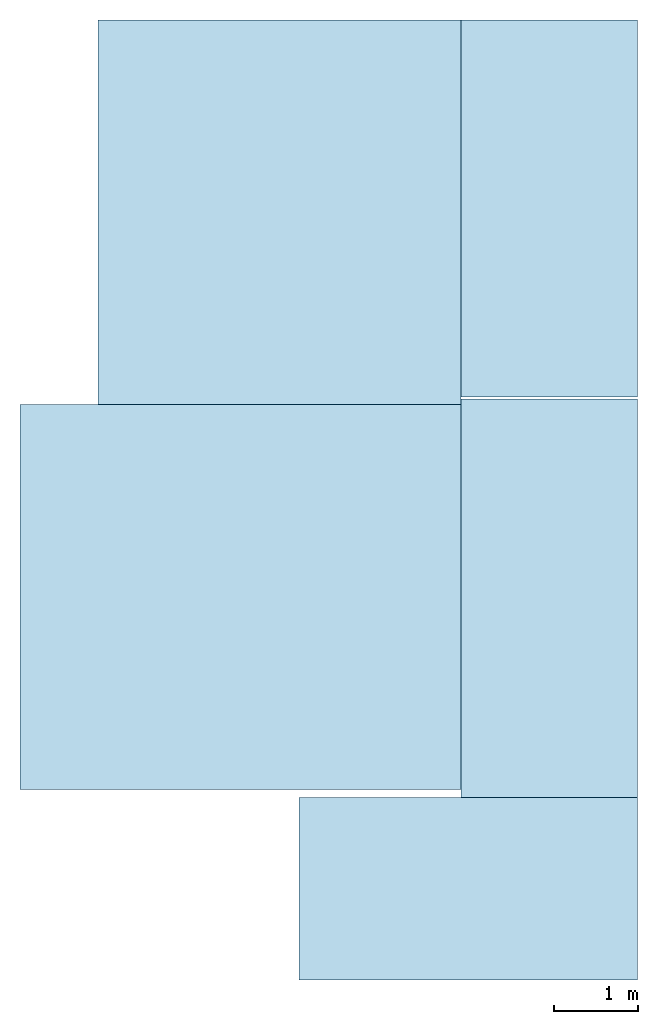
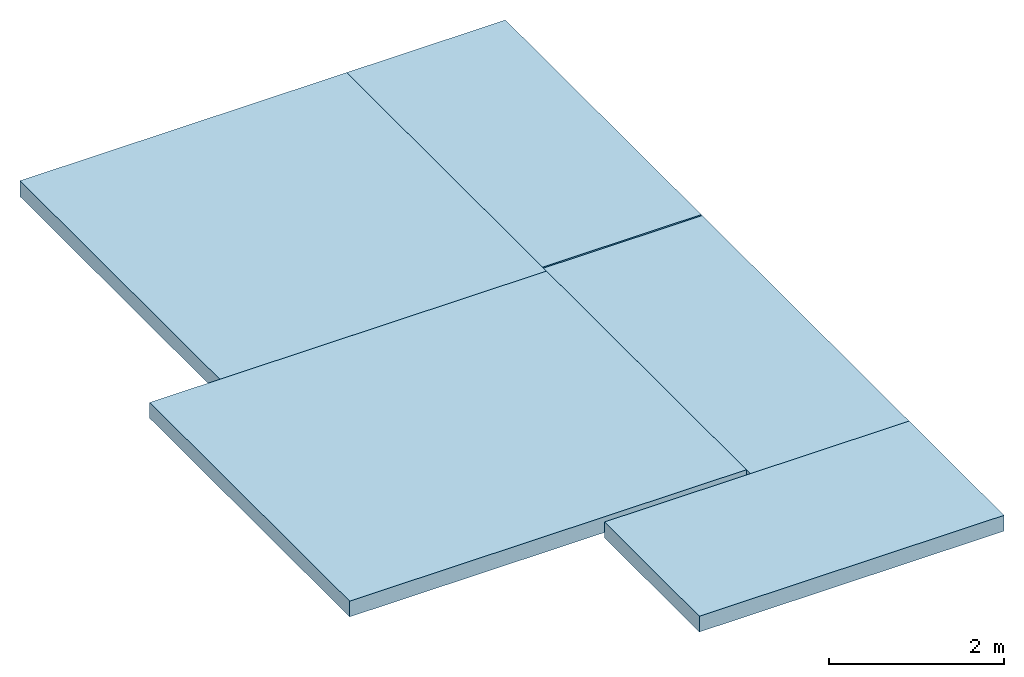
# One storey: 5 slabs.
"""IFC2X3 building model written with IfcOpenShell, lengths in millimetres."""

import ifcopenshell
import ifcopenshell.guid

model = None  # the IFC model being written
_history = None  # IfcOwnerHistory: only IFC2X3 demands one
_inside = {}  # id of a spatial element -> (the spatial element, [elements in it])
_under = {}  # id of a project, library or spatial element -> (it, [spatial elements below it])
_declared = {}  # id of a project -> (the project, [libraries it declares])
_typed = {}  # id of a type object -> (the type object, [elements of that type])
_made_of = {}  # id of a material, layer set ... -> (it, [elements and type objects made of it])


def new_model(schema):
    """Start an empty IFC model of exactly this schema.

    Asked for "IFC4X3", IfcOpenShell would pick the latest addendum, in which some entities
    have other attributes; the version numbers below select the first issue.
    IFC2X3 requires an IfcOwnerHistory on every rooted entity: one is made here for all.
    """
    global model, _history
    if schema == "IFC4X3":
        model = ifcopenshell.file(schema_version=(4, 3, 0, 0))
    else:
        model = ifcopenshell.file(schema=schema)
    _inside.clear()
    _under.clear()
    _declared.clear()
    _typed.clear()
    _made_of.clear()
    _history = None
    if model.schema == "IFC2X3":
        org = make("IfcOrganization", Name="unknown")
        user = make(
            "IfcPersonAndOrganization",
            ThePerson=make("IfcPerson", FamilyName="unknown"),
            TheOrganization=org,
        )
        app = make(
            "IfcApplication",
            ApplicationDeveloper=org,
            Version="unknown",
            ApplicationFullName="unknown",
            ApplicationIdentifier="unknown",
        )
        _history = make(
            "IfcOwnerHistory",
            OwningUser=user,
            OwningApplication=app,
            ChangeAction="ADDED",
            CreationDate=0,
        )
    return model


def make(cls, **values):
    """One entity of the class cls with the attributes given. An attribute that is None is left unset."""
    return model.create_entity(
        cls, **{name: value for name, value in values.items() if value is not None}
    )


def entity(cls, *values):
    """Any entity or typed value of the class cls, its attributes in the order of the schema. None: left unset."""
    e = model.create_entity(cls)
    for i, value in enumerate(values):
        if value is not None:
            e[i] = value
    return e


def rooted(cls, **values):
    """An entity with a GlobalId (a new one), such as an element, a storey or a relation."""
    return make(cls, GlobalId=ifcopenshell.guid.new(), OwnerHistory=_history, **values)


def si_unit(unit_type, name, prefix=None):
    """IfcSIUnit, for example si_unit("LENGTHUNIT", "METRE", prefix="MILLI")."""
    return make("IfcSIUnit", UnitType=unit_type, Prefix=prefix, Name=name)


def converted_unit(unit_type, name, factor, base, dimensions=None, offset=None):
    """IfcConversionBasedUnit, such as the inch: factor (a typed value) times the base unit."""
    return make(
        "IfcConversionBasedUnit"
        if offset is None
        else "IfcConversionBasedUnitWithOffset",
        ConversionOffset=offset,
        Dimensions=None
        if dimensions is None
        else entity("IfcDimensionalExponents", *dimensions),
        UnitType=unit_type,
        Name=name,
        ConversionFactor=make(
            "IfcMeasureWithUnit", ValueComponent=factor, UnitComponent=base
        ),
    )


def assignment(units):
    """IfcUnitAssignment: the units of a project."""
    return None if units is None else make("IfcUnitAssignment", Units=units)


def point(xyz):
    """IfcCartesianPoint."""
    return None if xyz is None else make("IfcCartesianPoint", Coordinates=xyz)


def direction(xyz):
    """IfcDirection."""
    return None if xyz is None else make("IfcDirection", DirectionRatios=xyz)


def frame(location, z_axis=None, x_axis=None):
    """IfcAxis2Placement3D, a coordinate frame: its origin and axes. An axis left out is left unset."""
    return make(
        "IfcAxis2Placement3D",
        Location=point(location),
        Axis=direction(z_axis),
        RefDirection=direction(x_axis),
    )


def frame_2d(location, x_axis=None):
    """IfcAxis2Placement2D, a coordinate frame in the plane: its origin and x axis."""
    return make(
        "IfcAxis2Placement2D", Location=point(location), RefDirection=direction(x_axis)
    )


def origin():
    """The frame at (0, 0, 0) with its axes left unset."""
    return frame((0.0, 0.0, 0.0))


def place(relative_to, where):
    """IfcLocalPlacement: puts the frame where relative to a parent placement (None: the world)."""
    return make(
        "IfcLocalPlacement", PlacementRelTo=relative_to, RelativePlacement=where
    )


def context(
    kind, dimensions, precision=None, world=None, true_north=None, identifier=None
):
    """IfcGeometricRepresentationContext, for example the 3D "Model" context."""
    return make(
        "IfcGeometricRepresentationContext",
        ContextIdentifier=identifier,
        ContextType=kind,
        CoordinateSpaceDimension=dimensions,
        Precision=precision,
        WorldCoordinateSystem=world,
        TrueNorth=true_north,
    )


def project(units=None, contexts=None):
    """IfcProject with its units and contexts."""
    return rooted(
        "IfcProject",
        Name="project",
        RepresentationContexts=contexts,
        UnitsInContext=assignment(units),
    )


def spatial(cls, under=None, at=None, **own):
    """A site, building, storey or space (cls), placed at a placement, below another one or the project."""
    s = rooted(cls, ObjectPlacement=at, **own)
    if under is not None:
        _under.setdefault(under.id(), (under, []))[1].append(s)
    return s


def profile(cls, at=None, kind="AREA", **sizes):
    """A parametric profile (cls). Its sizes go by their IFC names, for example OverallWidth=200.0."""
    return make(cls, ProfileType=kind, Position=at, **sizes)


def rectangle(**sizes):
    """IfcRectangleProfileDef."""
    return profile("IfcRectangleProfileDef", **sizes)


def extrude(swept, where, along, depth):
    """IfcExtrudedAreaSolid: the profile swept, set in the frame where, extruded along a direction by depth."""
    return make(
        "IfcExtrudedAreaSolid",
        SweptArea=swept,
        Position=where,
        ExtrudedDirection=direction(along),
        Depth=depth,
    )


def shape(context_of_items, identifier, shape_type, items):
    """IfcShapeRepresentation: the items that make up one representation, for example the "Body"."""
    return make(
        "IfcShapeRepresentation",
        ContextOfItems=context_of_items,
        RepresentationIdentifier=identifier,
        RepresentationType=shape_type,
        Items=items,
    )


def material(Name=None, Category=None):
    """IfcMaterial."""
    return make("IfcMaterial", Name=Name, Category=Category)


def layer(
    of_material, thickness, ventilated=None, Name=None, Category=None, Priority=None
):
    """IfcMaterialLayer: one layer of a wall or slab, of a material (None: an air gap)."""
    return make(
        "IfcMaterialLayer",
        Material=of_material,
        LayerThickness=thickness,
        IsVentilated=ventilated,
        Name=Name,
        Category=Category,
        Priority=Priority,
    )


def layer_set(layers, Name=None):
    """IfcMaterialLayerSet."""
    return make("IfcMaterialLayerSet", MaterialLayers=layers, LayerSetName=Name)


def layer_usage(for_layer_set, set_direction, sense, offset, extent=None):
    """IfcMaterialLayerSetUsage: how a layer set lies in its element."""
    return make(
        "IfcMaterialLayerSetUsage",
        ForLayerSet=for_layer_set,
        LayerSetDirection=set_direction,
        DirectionSense=sense,
        OffsetFromReferenceLine=offset,
        ReferenceExtent=extent,
    )


def made_of(thing, what):
    """Note that an element or type object is made of a material, layer set ...; save() writes the relation."""
    if what is not None:
        _made_of.setdefault(what.id(), (what, []))[1].append(thing)
    return thing


def element(
    cls,
    number,
    at=None,
    inside=None,
    cuts=None,
    type_object=None,
    material=None,
    context=None,
    identifier="Body",
    shape_type=None,
    held_by="IfcProductDefinitionShape",
    body=None,
    shapes=None,
    **own,
):
    """One element of the class cls, such as IfcWall. Its Tag is "e" and its number.

    at: its placement. inside: the storey or other place that contains it. cuts: it is an
    opening in that element (IfcRelVoidsElement). A single representation is given by context,
    identifier, shape_type and body (its items); several are given by shapes. held_by: the class
    of the entity that holds the representations. save() writes the other relations.
    """
    e = rooted(cls, Tag="e%d" % number, ObjectPlacement=at, **own)
    if body is not None:
        shapes = [shape(context, identifier, shape_type, body)]
    if shapes is not None:
        e.Representation = make(held_by, Representations=shapes)
    if inside is not None:
        _inside.setdefault(inside.id(), (inside, []))[1].append(e)
    if cuts is not None:
        rooted(
            "IfcRelVoidsElement", RelatingBuildingElement=cuts, RelatedOpeningElement=e
        )
    if type_object is not None:
        _typed.setdefault(type_object.id(), (type_object, []))[1].append(e)
    return made_of(e, material)


def aggregate(whole, parts):
    """IfcRelAggregates: a whole, such as a stair, and the parts it consists of."""
    return rooted("IfcRelAggregates", RelatingObject=whole, RelatedObjects=parts)


def save(model, path):
    """Write the relations noted so far, then the file.

    IfcRelAggregates (storeys below a building ...), IfcRelContainedInSpatialStructure (elements
    in a storey), IfcRelDefinesByType, IfcRelAssociatesMaterial and IfcRelDeclares: one each for
    every whole, place, type object, material and project.
    """
    for whole, parts in _under.values():
        aggregate(whole, parts)
    for where, things in _inside.values():
        rooted(
            "IfcRelContainedInSpatialStructure",
            RelatedElements=things,
            RelatingStructure=where,
        )
    for kind, things in _typed.values():
        rooted("IfcRelDefinesByType", RelatedObjects=things, RelatingType=kind)
    for what, things in _made_of.values():
        rooted("IfcRelAssociatesMaterial", RelatedObjects=things, RelatingMaterial=what)
    for by, libraries in _declared.values():
        rooted("IfcRelDeclares", RelatingContext=by, RelatedDefinitions=libraries)
    model.write(path)


model = new_model("IFC2X3")

# Units and contexts
model_context = context("Model", 3, precision=1e-06, world=origin())
plan_context = context("Plan", 3, precision=1e-06, world=origin())
ifc_project = project(units=[si_unit("LENGTHUNIT", "METRE", prefix="MILLI"), si_unit("AREAUNIT", "SQUARE_METRE", prefix="MILLI"), si_unit("VOLUMEUNIT", "CUBIC_METRE", prefix="MILLI"), converted_unit("PLANEANGLEUNIT", "DEGREE", entity("IfcRatioMeasure", 0.01745329251994328), si_unit("PLANEANGLEUNIT", "RADIAN"), dimensions=[0, 0, 0, 0, 0, 0, 0]), si_unit("TIMEUNIT", "SECOND")], contexts=[model_context, plan_context])

# Site, building, storey
site_placement = place(None, origin())
site = spatial("IfcSite", under=ifc_project, at=site_placement, CompositionType="ELEMENT")
building_placement = place(None, origin())
building = spatial("IfcBuilding", under=site, at=building_placement, CompositionType="ELEMENT")
storey_placement = place(building_placement, frame((0.0, 0.0, 11250.0)))
storey = spatial("IfcBuildingStorey", under=building, at=storey_placement, Name="Level 4", CompositionType="ELEMENT", Elevation=11250.0)

# Slabs
ifc_material = material(Name="Concrete - Cast In Situ")
ifc_layer = layer(ifc_material, 220.0)
ifc_layer_set = layer_set([ifc_layer], Name="Floor:Insitu Concrete 220mm")
ifc_layer_usage_1 = layer_usage(ifc_layer_set, "AXIS3", "POSITIVE", 0.0)
slab_1_placement = place(storey_placement, frame((-19247.18401022489, 2401.09876815164, -220.0)))
element("IfcSlab", 1, at=slab_1_placement, inside=storey, material=ifc_layer_usage_1, Name="Floor:Insitu Concrete 220mm", ObjectType="Floor:Insitu Concrete 220mm", PredefinedType="FLOOR", context=model_context, shape_type="SweptSolid", body=[
    extrude(rectangle(XDim=4570.000000000006, YDim=5250.000777799518, at=frame_2d((16622.18362132513, 4686.098768151644), x_axis=(0.0, -1.0))), frame((19247.18401022489, -2401.09876815164, 220.0), z_axis=(0.0, 0.0, -1.0), x_axis=(-1.0, 0.0, 0.0)), (0.0, 0.0, 1.0), 220.0),
])
ifc_layer_usage_2 = layer_usage(ifc_layer_set, "AXIS3", "POSITIVE", 0.0)
slab_2_placement = place(storey_placement, frame((-18322.18323242538, 6971.098768151646, -220.0)))
element("IfcSlab", 2, at=slab_2_placement, inside=storey, material=ifc_layer_usage_2, Name="Floor:Insitu Concrete 220mm", ObjectType="Floor:Insitu Concrete 220mm", PredefinedType="FLOOR", context=model_context, shape_type="SweptSolid", body=[
    extrude(rectangle(XDim=4567.302251788157, YDim=4310.557965402411, at=frame_2d((16166.90424972418, 9254.749894045724), x_axis=(0.0, -1.0))), frame((18322.18323242538, -6971.098768151646, 220.0), z_axis=(0.0, 0.0, -1.0), x_axis=(-1.0, 0.0, 0.0)), (0.0, 0.0, 1.0), 220.0),
])
ifc_layer_usage_3 = layer_usage(ifc_layer_set, "AXIS3", "POSITIVE", 0.0)
slab_3_placement = place(storey_placement, frame((-14011.62526702297, 7061.098768151647, -220.0)))
element("IfcSlab", 3, at=slab_3_placement, inside=storey, material=ifc_layer_usage_3, Name="Floor:Insitu Concrete 220mm", ObjectType="Floor:Insitu Concrete 220mm", PredefinedType="FLOOR", context=model_context, shape_type="SweptSolid", body=[
    extrude(rectangle(XDim=4477.302251788156, YDim=2094.442034597587, at=frame_2d((12964.40424972418, 9299.749894045726), x_axis=(0.0, -1.0))), frame((14011.62526702297, -7061.098768151647, 220.0), z_axis=(0.0, 0.0, -1.0), x_axis=(-1.0, 0.0, 0.0)), (0.0, 0.0, 1.0), 220.0),
])
ifc_layer_usage_4 = layer_usage(ifc_layer_set, "AXIS3", "POSITIVE", 0.0)
slab_4_placement = place(storey_placement, frame((-15937.18323242539, 142.3366320096107, -220.0)))
element("IfcSlab", 4, at=slab_4_placement, inside=storey, material=ifc_layer_usage_4, Name="Floor:Insitu Concrete 220mm", ObjectType="Floor:Insitu Concrete 220mm", PredefinedType="FLOOR", context=model_context, shape_type="SweptSolid", body=[
    extrude(rectangle(XDim=2168.762136142018, YDim=4019.999999999827, at=frame_2d((13927.18323242548, 1226.71770008062), x_axis=(0.0, -1.0))), frame((15937.18323242539, -142.3366320096107, 220.0), z_axis=(0.0, 0.0, -1.0), x_axis=(-1.0, 0.0, 0.0)), (0.0, 0.0, 1.0), 220.0),
])
ifc_layer_usage_5 = layer_usage(ifc_layer_set, "AXIS3", "POSITIVE", 0.0)
slab_5_placement = place(storey_placement, frame((-14011.62526702297, 2311.098768151617, -220.0)))
element("IfcSlab", 5, at=slab_5_placement, inside=storey, material=ifc_layer_usage_5, Name="Floor:Insitu Concrete 220mm", ObjectType="Floor:Insitu Concrete 220mm", PredefinedType="FLOOR", context=model_context, shape_type="SweptSolid", body=[
    extrude(rectangle(XDim=4728.20000000003, YDim=2094.442034597589, at=frame_2d((12964.40424972418, 4675.198768151632), x_axis=(0.0, -1.0))), frame((14011.62526702297, -2311.098768151617, 220.0), z_axis=(0.0, 0.0, -1.0), x_axis=(-1.0, 0.0, 0.0)), (0.0, 0.0, 1.0), 220.0),
])

save(model, "model.ifc")
